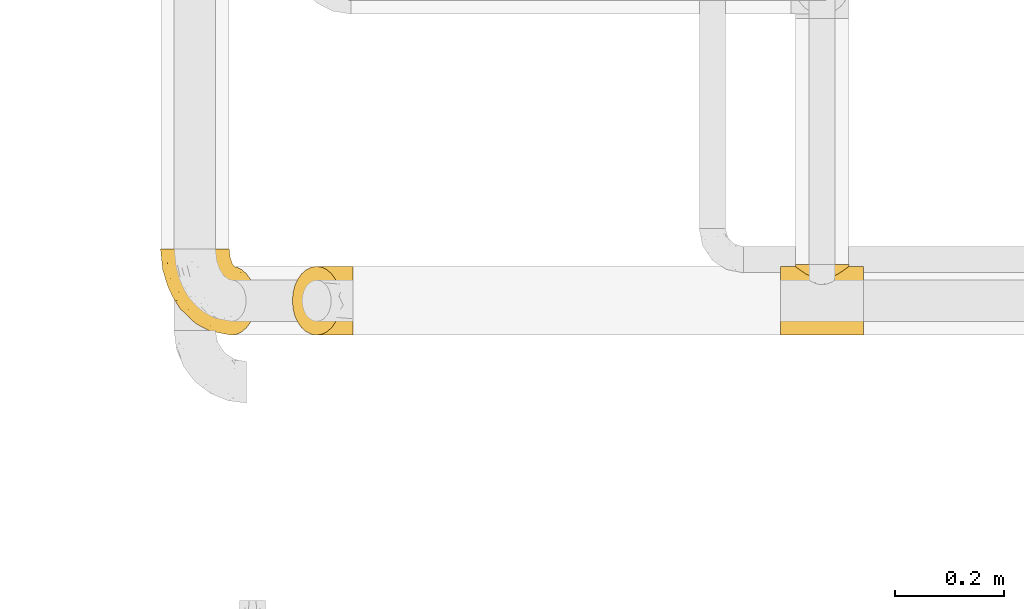
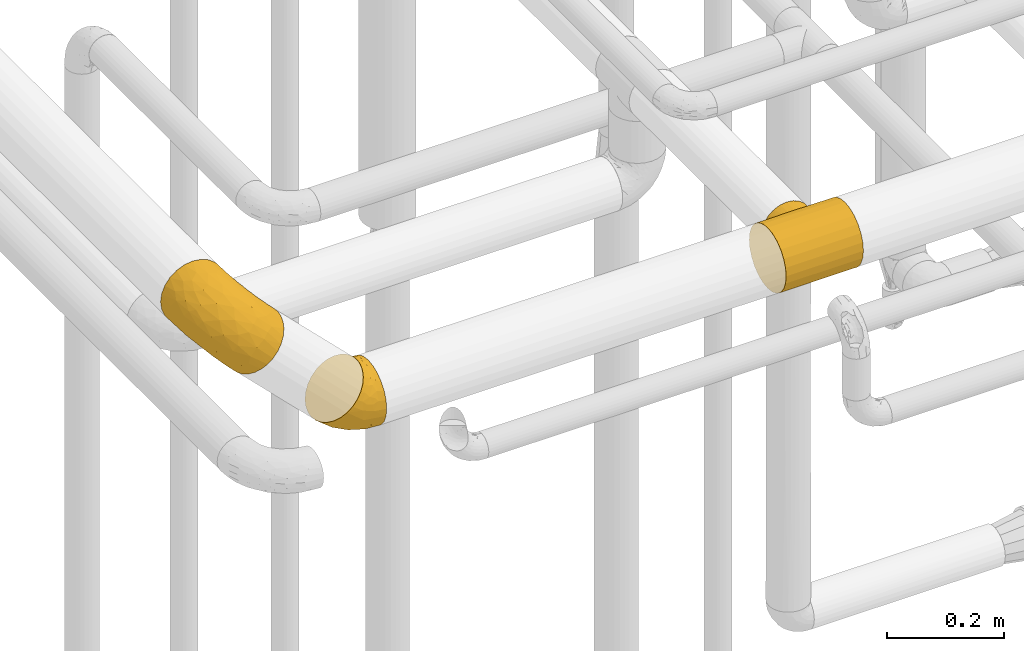
# One storey, part 418 of 827: 3 coverings.
"""IFC2X3 building model written with IfcOpenShell, lengths in millimetres."""

from ifc_helpers import new_model, entity, si_unit, converted_unit, derived_unit, direction, frame, origin, place, context, subcontext, project, spatial, faceted_brep, element, save


model = new_model("IFC2X3")

# Units and contexts
model_context = context("Model", 3, precision=0.01, world=origin(), true_north=direction((6.12303176911189e-17, 1.0)))
body_context = subcontext(model_context, "Body", "Model", "MODEL_VIEW")
ifc_project = project(units=[si_unit("LENGTHUNIT", "METRE", prefix="MILLI"), si_unit("AREAUNIT", "SQUARE_METRE"), si_unit("VOLUMEUNIT", "CUBIC_METRE"), converted_unit("PLANEANGLEUNIT", "DEGREE", entity("IfcRatioMeasure", 0.0174532925199433), si_unit("PLANEANGLEUNIT", "RADIAN"), dimensions=[0, 0, 0, 0, 0, 0, 0]), si_unit("MASSUNIT", "GRAM", prefix="KILO"), derived_unit("MASSDENSITYUNIT", [(si_unit("MASSUNIT", "GRAM", prefix="KILO"), 1), (si_unit("LENGTHUNIT", "METRE"), -3)]), derived_unit("MOMENTOFINERTIAUNIT", [(si_unit("LENGTHUNIT", "METRE"), 4)]), si_unit("TIMEUNIT", "SECOND"), si_unit("FREQUENCYUNIT", "HERTZ"), si_unit("THERMODYNAMICTEMPERATUREUNIT", "DEGREE_CELSIUS"), derived_unit("THERMALTRANSMITTANCEUNIT", [(si_unit("MASSUNIT", "GRAM", prefix="KILO"), 1), (si_unit("THERMODYNAMICTEMPERATUREUNIT", "KELVIN"), -1), (si_unit("TIMEUNIT", "SECOND"), -3)]), derived_unit("VOLUMETRICFLOWRATEUNIT", [(si_unit("LENGTHUNIT", "METRE"), 3), (si_unit("TIMEUNIT", "SECOND"), -1)]), derived_unit("MASSFLOWRATEUNIT", [(si_unit("MASSUNIT", "GRAM", prefix="KILO"), 1), (si_unit("TIMEUNIT", "SECOND"), -1)]), derived_unit("ROTATIONALFREQUENCYUNIT", [(si_unit("TIMEUNIT", "SECOND"), -1)]), si_unit("ELECTRICCURRENTUNIT", "AMPERE"), si_unit("ELECTRICVOLTAGEUNIT", "VOLT"), si_unit("POWERUNIT", "WATT"), si_unit("FORCEUNIT", "NEWTON", prefix="KILO"), si_unit("ILLUMINANCEUNIT", "LUX"), si_unit("LUMINOUSFLUXUNIT", "LUMEN"), si_unit("LUMINOUSINTENSITYUNIT", "CANDELA"), derived_unit("USERDEFINED", [(si_unit("MASSUNIT", "GRAM", prefix="KILO"), -1), (si_unit("LENGTHUNIT", "METRE"), -2), (si_unit("TIMEUNIT", "SECOND"), 3), (si_unit("LUMINOUSFLUXUNIT", "LUMEN"), 1)]), derived_unit("LINEARVELOCITYUNIT", [(si_unit("LENGTHUNIT", "METRE"), 1), (si_unit("TIMEUNIT", "SECOND"), -1)]), si_unit("PRESSUREUNIT", "PASCAL"), derived_unit("USERDEFINED", [(si_unit("LENGTHUNIT", "METRE"), -2), (si_unit("MASSUNIT", "GRAM", prefix="KILO"), 1), (si_unit("TIMEUNIT", "SECOND"), -2)]), derived_unit("LINEARFORCEUNIT", [(si_unit("MASSUNIT", "GRAM", prefix="KILO"), 1), (si_unit("LENGTHUNIT", "METRE"), 1), (si_unit("TIMEUNIT", "SECOND"), -2), (si_unit("LENGTHUNIT", "METRE"), -1)]), derived_unit("PLANARFORCEUNIT", [(si_unit("MASSUNIT", "GRAM", prefix="KILO"), 1), (si_unit("LENGTHUNIT", "METRE"), 1), (si_unit("TIMEUNIT", "SECOND"), -2), (si_unit("LENGTHUNIT", "METRE"), -2)])], contexts=[model_context])

# Site, building, storey
site_placement = place(None, origin())
site = spatial("IfcSite", under=ifc_project, at=site_placement, CompositionType="ELEMENT")
building_placement = place(site_placement, origin())
building = spatial("IfcBuilding", under=site, at=building_placement, CompositionType="ELEMENT")
storey_placement = place(building_placement, frame((0.0, 0.0, 28200.0)))
storey = spatial("IfcBuildingStorey", under=building, at=storey_placement, Name="08", CompositionType="ELEMENT", Elevation=28200.0)

# Coverings
covering_1_placement = place(storey_placement, frame((51903.73, 16007.73, 2836.71)))
element("IfcCovering", 1, at=covering_1_placement, inside=storey, Name=":ADSK_", ObjectType=":ADSK_", PredefinedType="INSULATION", context=body_context, shape_type="Brep", body=[
    faceted_brep([(175.35, 50.62, 89.9), (172.07, 37.29, 86.6), (166.77, 25.34, 81.27), (159.73, 15.35, 74.19), (151.31, 7.84, 65.71), (141.91, 3.18, 56.26), (132.02, 1.6, 46.31), (122.13, 3.18, 36.36), (112.73, 7.84, 26.91), (104.3, 15.35, 18.43), (97.27, 25.33, 11.35), (91.97, 37.29, 6.02), (88.68, 50.61, 2.72), (87.57, 64.65, 1.6), (88.68, 78.67, 2.72), (91.97, 92.0, 6.02), (97.26, 103.95, 11.35), (104.3, 113.94, 18.43), (112.73, 121.45, 26.91), (122.12, 126.11, 36.36), (132.02, 127.7, 46.31), (141.91, 126.11, 56.26), (151.3, 121.45, 65.71), (159.73, 113.94, 74.19), (166.77, 103.96, 81.27), (172.07, 92.0, 86.59), (175.35, 78.68, 89.9), (176.47, 64.65, 91.02), (109.36, 159.65, 68.83), (96.33, 159.65, 58.78), (81.14, 159.65, 52.43), (64.83, 159.65, 50.24), (48.51, 159.65, 52.34), (33.28, 159.65, 58.59), (28.78, 159.65, 62.02), (20.19, 159.65, 68.57), (10.14, 159.65, 81.6), (3.79, 159.65, 96.79), (1.6, 159.65, 113.1), (3.7, 159.65, 129.43), (9.95, 159.65, 144.65), (19.93, 159.65, 157.74), (32.96, 159.65, 167.8), (48.15, 159.65, 174.14), (64.46, 159.65, 176.34), (80.78, 159.65, 174.24), (96.01, 159.65, 167.98), (109.1, 159.65, 158.0), (115.7, 159.65, 149.45), (119.15, 159.65, 144.97), (125.5, 159.65, 129.78), (127.69, 159.65, 113.47), (125.59, 159.65, 97.15), (119.34, 159.65, 81.92), (55.85, 131.11, 173.43), (41.66, 121.84, 167.26), (60.37, 98.59, 165.56), (30.26, 132.73, 163.38), (23.75, 118.74, 153.94), (115.09, 45.67, 131.87), (95.71, 62.3, 147.86), (83.02, 49.95, 140.46), (58.27, 65.74, 147.01), (34.95, 80.62, 142.81), (52.76, 47.89, 125.1), (86.52, 117.53, 168.96), (83.08, 90.48, 162.78), (100.43, 98.53, 159.78), (97.71, 128.08, 165.64), (109.77, 107.83, 155.85), (117.7, 30.59, 118.55), (106.34, 23.56, 112.96), (128.56, 14.41, 94.06), (48.91, 94.66, 160.6), (35.83, 103.54, 157.62), (72.38, 121.36, 172.36), (103.01, 6.98, 75.15), (118.58, 9.17, 86.36), (76.46, 35.7, 124.55), (93.76, 18.43, 103.65), (129.71, 57.25, 130.67), (120.01, 81.84, 144.59), (109.87, 72.43, 147.74), (157.78, 56.38, 108.16), (151.24, 43.86, 108.97), (121.96, 103.81, 145.21), (117.18, 117.05, 149.97), (112.39, 130.29, 154.72), (140.64, 21.28, 97.63), (136.51, 34.21, 112.94), (75.74, 74.07, 156.07), (136.87, 82.79, 130.39), (133.14, 88.04, 134.1), (129.42, 93.3, 137.8), (167.68, 66.61, 99.76), (161.66, 67.95, 105.74), (155.65, 69.29, 111.72), (138.98, 66.64, 126.81), (146.26, 76.04, 121.06), (75.97, 22.77, 102.02), (110.49, 147.25, 156.62), (138.95, 120.78, 107.68), (135.84, 128.88, 94.92), (133.4, 132.53, 106.71), (118.56, 145.71, 146.5), (127.03, 132.18, 133.07), (123.45, 121.21, 142.13), (128.82, 115.88, 135.23), (120.97, 134.78, 143.82), (134.18, 113.68, 126.87), (133.01, 124.96, 121.96), (158.42, 105.67, 88.96), (148.96, 116.22, 85.8), (151.61, 103.69, 102.12), (127.74, 149.68, 102.67), (129.9, 142.04, 112.35), (124.93, 151.17, 92.07), (129.16, 140.2, 93.76), (125.43, 145.72, 132.4), (120.15, 147.4, 78.91), (133.11, 128.57, 65.74), (125.59, 136.38, 74.91), (137.37, 126.93, 81.16), (157.1, 79.77, 108.94), (148.21, 89.98, 116.32), (165.6, 79.6, 99.68), (120.69, 131.98, 57.57), (159.37, 90.59, 101.79), (127.75, 129.31, 50.55), (131.63, 133.25, 84.68), (142.77, 119.53, 95.49), (144.86, 111.1, 106.35), (128.26, 143.67, 122.92), (142.95, 123.62, 71.67), (145.48, 100.76, 114.84), (112.39, 143.67, 65.82), (130.77, 104.28, 135.16), (139.87, 112.26, 116.34), (137.88, 103.95, 125.18), (141.0, 92.99, 124.55), (86.22, 151.17, 53.13), (76.66, 144.66, 49.2), (99.35, 147.4, 57.98), (21.59, 147.25, 67.19), (112.6, 128.57, 45.1), (103.38, 136.38, 52.57), (53.79, 93.43, 36.99), (64.24, 100.15, 31.77), (62.11, 89.98, 29.71), (33.06, 103.81, 55.78), (28.28, 117.05, 60.54), (36.15, 121.21, 54.32), (76.32, 103.69, 26.39), (70.21, 110.23, 33.42), (81.95, 118.45, 34.66), (34.44, 134.78, 56.78), (45.23, 132.18, 50.79), (55.39, 143.67, 49.61), (65.97, 142.04, 48.04), (70.69, 120.78, 39.02), (72.61, 132.4, 44.45), (83.49, 127.76, 41.42), (45.89, 145.72, 52.39), (31.75, 145.71, 59.18), (56.37, 124.96, 44.88), (106.72, 123.62, 35.23), (84.55, 140.2, 48.89), (78.77, 66.61, 10.34), (72.76, 67.95, 16.31), (97.19, 126.93, 40.75), (92.62, 116.21, 29.13), (76.69, 90.59, 18.63), (69.54, 79.77, 20.85), (89.52, 105.66, 19.65), (66.75, 69.29, 22.29), (78.84, 79.6, 12.41), (93.11, 133.38, 46.47), (47.97, 82.79, 40.96), (57.36, 76.04, 31.63), (43.17, 104.28, 47.03), (43.08, 115.88, 48.98), (51.48, 113.68, 43.67), (61.25, 112.97, 38.69), (40.51, 93.3, 48.37), (53.18, 103.94, 39.99), (23.49, 130.29, 65.29), (12.35, 98.59, 117.25), (4.45, 131.11, 121.73), (5.62, 121.36, 105.2), (9.1, 117.53, 91.08), (10.54, 121.84, 135.95), (19.62, 105.45, 142.34), (14.36, 132.83, 147.44), (22.35, 107.83, 67.91), (70.32, 56.38, 20.18), (69.48, 43.85, 26.72), (47.65, 57.25, 48.12), (53.45, 35.7, 101.41), (37.58, 49.95, 94.75), (65.22, 23.55, 71.6), (51.56, 66.64, 38.87), (33.67, 81.84, 57.74), (12.49, 128.08, 79.91), (18.34, 92.46, 128.9), (59.7, 30.58, 60.21), (80.75, 21.27, 37.39), (90.12, 12.64, 43.48), (46.36, 45.66, 62.73), (65.42, 34.21, 41.43), (15.26, 90.48, 94.56), (30.88, 65.74, 119.46), (18.37, 98.53, 77.23), (30.46, 72.43, 67.86), (30.25, 62.3, 82.02), (23.7, 72.15, 109.34), (27.05, 82.52, 134.73), (72.89, 19.03, 82.69), (91.89, 9.17, 59.51)], [[[0, 1, 2, 3, 4, 5, 6, 7, 8, 9, 10, 11, 12, 13, 14, 15, 16, 17, 18, 19, 20, 21, 22, 23, 24, 25, 26, 27]], [[28, 29, 30, 31, 32, 33, 34, 35, 36, 37, 38, 39, 40, 41, 42, 43, 44, 45, 46, 47, 48, 49, 50, 51, 52, 53]], [[54, 55, 56]], [[57, 41, 58]], [[59, 60, 61]], [[62, 63, 64]], [[65, 66, 67]], [[68, 67, 69]], [[70, 71, 72]], [[55, 73, 56]], [[43, 42, 55]], [[55, 74, 73]], [[44, 75, 45]], [[44, 43, 54]], [[76, 5, 77]], [[71, 78, 79]], [[45, 75, 65]], [[46, 68, 47]], [[80, 81, 82]], [[0, 83, 84]], [[69, 85, 86, 87]], [[69, 81, 85]], [[84, 1, 0]], [[2, 88, 3]], [[4, 3, 72]], [[44, 54, 75]], [[5, 4, 77]], [[89, 2, 1]], [[72, 3, 88]], [[5, 76, 6]], [[70, 88, 89]], [[68, 65, 67]], [[88, 2, 89]], [[56, 90, 66]], [[64, 78, 62]], [[81, 91, 92, 93, 85]], [[83, 27, 94, 95, 96]], [[62, 61, 90]], [[97, 96, 98, 91]], [[80, 97, 81]], [[42, 57, 55]], [[62, 78, 61]], [[84, 89, 1]], [[78, 64, 99]], [[57, 74, 55]], [[76, 77, 79]], [[77, 72, 71]], [[82, 81, 67]], [[97, 83, 96]], [[80, 89, 84]], [[79, 78, 99]], [[71, 70, 61]], [[81, 97, 91]], [[83, 80, 84]], [[68, 87, 100, 47]], [[81, 69, 67]], [[68, 69, 87]], [[65, 46, 45]], [[65, 68, 46]], [[66, 65, 75]], [[56, 66, 75]], [[66, 60, 82]], [[71, 61, 78]], [[60, 66, 90]], [[83, 97, 80]], [[27, 83, 0]], [[59, 70, 89]], [[70, 59, 61]], [[89, 80, 59]], [[82, 59, 80]], [[55, 54, 43]], [[75, 54, 56]], [[66, 82, 67]], [[59, 82, 60]], [[41, 57, 42]], [[74, 57, 58]], [[58, 63, 74]], [[62, 74, 63]], [[74, 62, 73]], [[62, 56, 73]], [[4, 72, 77]], [[70, 72, 88]], [[76, 79, 99]], [[71, 79, 77]], [[62, 90, 56]], [[60, 90, 61]], [[101, 102, 103]], [[100, 87, 104]], [[105, 106, 107]], [[108, 104, 87]], [[107, 109, 110]], [[108, 87, 86]], [[111, 112, 113]], [[114, 51, 115]], [[116, 114, 117]], [[51, 50, 118]], [[119, 28, 53]], [[120, 121, 122]], [[98, 123, 124]], [[125, 96, 95]], [[116, 53, 52]], [[126, 121, 120]], [[104, 108, 118]], [[98, 124, 91]], [[25, 24, 127]], [[120, 128, 126]], [[122, 129, 102]], [[95, 94, 27, 26]], [[122, 102, 130]], [[125, 127, 123]], [[24, 111, 127]], [[21, 20, 128]], [[112, 130, 131]], [[48, 47, 100, 49]], [[132, 110, 115]], [[23, 111, 24]], [[129, 119, 117]], [[120, 133, 21]], [[112, 23, 22]], [[134, 113, 131]], [[121, 126, 135]], [[133, 112, 22]], [[128, 120, 21]], [[132, 51, 118]], [[120, 122, 133]], [[119, 121, 135]], [[129, 117, 102]], [[125, 26, 25]], [[26, 125, 95]], [[127, 125, 25]], [[28, 119, 135]], [[119, 53, 116]], [[127, 113, 124]], [[96, 125, 123]], [[112, 131, 113]], [[101, 103, 110]], [[85, 93, 136]], [[124, 123, 127]], [[98, 96, 123]], [[112, 111, 23]], [[127, 111, 113]], [[112, 133, 122]], [[21, 133, 22]], [[107, 110, 105]], [[110, 109, 137]], [[86, 106, 108]], [[138, 109, 136]], [[105, 118, 108]], [[107, 106, 85]], [[104, 50, 49]], [[124, 134, 139]], [[138, 93, 92]], [[92, 91, 139]], [[100, 104, 49]], [[118, 105, 132]], [[104, 118, 50]], [[110, 132, 105]], [[51, 132, 115]], [[108, 106, 105]], [[85, 106, 86]], [[114, 116, 52]], [[119, 116, 117]], [[51, 114, 52]], [[114, 115, 103]], [[117, 114, 103]], [[130, 102, 101]], [[117, 103, 102]], [[110, 103, 115]], [[130, 101, 131]], [[122, 130, 112]], [[101, 137, 131]], [[113, 134, 124]], [[137, 134, 131]], [[124, 139, 91]], [[134, 138, 139]], [[92, 139, 138]], [[110, 137, 101]], [[134, 137, 138]], [[136, 109, 107]], [[137, 109, 138]], [[85, 136, 107]], [[138, 136, 93]], [[122, 121, 129]], [[129, 121, 119]], [[30, 140, 141]], [[30, 29, 140]], [[28, 135, 142]], [[143, 35, 34, 33]], [[19, 144, 128]], [[126, 145, 135]], [[146, 147, 148]], [[149, 150, 151]], [[152, 153, 154]], [[155, 156, 151]], [[157, 31, 158]], [[159, 160, 161]], [[32, 162, 163]], [[158, 31, 30]], [[157, 164, 156]], [[126, 144, 145]], [[126, 128, 144]], [[18, 165, 19]], [[141, 166, 160]], [[14, 13, 167, 168]], [[163, 143, 33]], [[169, 165, 170]], [[18, 17, 170]], [[153, 159, 154]], [[142, 135, 145]], [[148, 171, 172]], [[159, 161, 154]], [[171, 152, 173]], [[173, 17, 16]], [[16, 15, 171]], [[158, 160, 164]], [[174, 175, 168]], [[173, 170, 17]], [[19, 128, 20]], [[174, 172, 175]], [[165, 169, 144]], [[162, 157, 156]], [[175, 172, 171]], [[144, 169, 145]], [[176, 169, 161]], [[166, 140, 142]], [[175, 171, 15]], [[168, 175, 14]], [[14, 175, 15]], [[142, 145, 176]], [[28, 142, 29]], [[148, 177, 146]], [[148, 178, 177]], [[152, 171, 148]], [[179, 180, 181]], [[164, 180, 156]], [[174, 178, 172]], [[148, 172, 178]], [[171, 173, 16]], [[170, 173, 152]], [[19, 165, 144]], [[170, 165, 18]], [[153, 182, 159]], [[146, 183, 184]], [[181, 180, 164]], [[180, 151, 156]], [[163, 155, 185]], [[155, 150, 185]], [[162, 156, 155]], [[143, 163, 185]], [[180, 179, 149]], [[32, 163, 33]], [[163, 162, 155]], [[31, 162, 32]], [[31, 157, 162]], [[164, 157, 158]], [[149, 151, 180]], [[155, 151, 150]], [[142, 140, 29]], [[141, 140, 166]], [[176, 145, 169]], [[30, 141, 158]], [[164, 160, 159]], [[158, 141, 160]], [[166, 161, 160]], [[154, 169, 170]], [[169, 154, 161]], [[152, 154, 170]], [[147, 152, 148]], [[153, 147, 182]], [[181, 182, 184]], [[164, 159, 182]], [[161, 166, 176]], [[142, 176, 166]], [[183, 146, 177]], [[184, 182, 147]], [[184, 147, 146]], [[152, 147, 153]], [[182, 181, 164]], [[179, 184, 183]], [[184, 179, 181]], [[149, 179, 183]], [[186, 187, 188]], [[37, 36, 189]], [[190, 191, 192]], [[193, 185, 150, 149]], [[194, 195, 196]], [[197, 198, 199]], [[200, 201, 177]], [[193, 202, 185]], [[203, 190, 186]], [[202, 189, 36]], [[41, 40, 192]], [[204, 205, 199]], [[9, 8, 206]], [[187, 190, 39]], [[40, 39, 190]], [[38, 37, 188]], [[207, 208, 204]], [[202, 35, 143, 185]], [[39, 38, 187]], [[195, 11, 208]], [[201, 149, 183, 177]], [[188, 189, 209]], [[197, 64, 210]], [[186, 188, 209]], [[13, 12, 194]], [[211, 201, 212]], [[12, 11, 195]], [[193, 201, 211]], [[212, 201, 196]], [[10, 208, 11]], [[213, 214, 209]], [[64, 63, 215]], [[216, 197, 199]], [[8, 217, 206]], [[7, 217, 8]], [[203, 191, 190]], [[7, 6, 76]], [[208, 205, 204]], [[205, 10, 9]], [[199, 205, 206]], [[7, 76, 217]], [[205, 208, 10]], [[216, 76, 99]], [[200, 177, 178, 174]], [[64, 197, 99]], [[63, 58, 191]], [[208, 196, 195]], [[196, 200, 194]], [[198, 197, 210]], [[216, 199, 217]], [[201, 193, 149]], [[202, 193, 211]], [[202, 211, 189]], [[35, 202, 36]], [[211, 212, 209]], [[37, 189, 188]], [[211, 209, 189]], [[213, 198, 214]], [[200, 174, 194]], [[201, 200, 196]], [[214, 198, 210]], [[213, 207, 198]], [[194, 174, 168, 167, 13]], [[195, 194, 12]], [[198, 204, 199]], [[204, 198, 207]], [[212, 207, 213]], [[196, 208, 207]], [[188, 187, 38]], [[190, 187, 186]], [[207, 212, 196]], [[209, 212, 213]], [[214, 203, 186]], [[191, 215, 63]], [[191, 203, 215]], [[192, 191, 58]], [[41, 192, 58]], [[190, 192, 40]], [[203, 210, 215]], [[64, 215, 210]], [[199, 206, 217]], [[9, 206, 205]], [[76, 216, 217]], [[99, 197, 216]], [[203, 214, 210]], [[209, 214, 186]]]),
])
covering_2_placement = place(storey_placement, frame((52146.02, 16007.73, 2635.35)))
element("IfcCovering", 2, at=covering_2_placement, inside=storey, Name=":ADSK_", ObjectType=":ADSK_", PredefinedType="INSULATION", context=body_context, shape_type="Brep", body=[
    faceted_brep([(89.38, 78.67, 135.87), (86.1, 92.0, 132.56), (80.8, 103.95, 127.23), (73.76, 113.94, 120.15), (65.34, 121.45, 111.68), (55.94, 126.11, 102.23), (46.05, 127.7, 92.27), (36.16, 126.11, 82.32), (26.76, 121.45, 72.87), (18.33, 113.94, 64.39), (11.29, 103.96, 57.31), (6.0, 92.0, 51.99), (2.71, 78.68, 48.68), (1.6, 64.65, 47.56), (2.71, 50.62, 48.68), (6.0, 37.29, 51.99), (11.29, 25.34, 57.31), (18.33, 15.35, 64.39), (26.76, 7.84, 72.87), (36.15, 3.18, 82.32), (46.05, 1.6, 92.27), (55.94, 3.18, 102.22), (65.33, 7.84, 111.67), (73.76, 15.35, 120.15), (80.8, 25.33, 127.23), (86.1, 37.29, 132.56), (89.38, 50.61, 135.87), (90.5, 64.65, 136.99), (113.02, 64.65, 127.7), (113.02, 48.33, 125.55), (113.02, 33.12, 119.25), (113.02, 20.06, 109.23), (113.02, 10.04, 96.17), (113.02, 3.74, 80.96), (113.02, 1.6, 64.65), (113.02, 3.74, 48.33), (113.02, 10.04, 33.12), (113.02, 20.06, 20.06), (113.02, 33.12, 10.04), (113.02, 48.33, 3.74), (113.02, 64.65, 1.6), (113.02, 80.96, 3.74), (113.02, 96.17, 10.04), (113.02, 109.23, 20.06), (113.02, 119.25, 33.12), (113.02, 125.55, 48.33), (113.02, 127.7, 64.65), (113.02, 125.55, 80.96), (113.02, 119.25, 96.17), (113.02, 109.23, 109.23), (113.02, 96.17, 119.25), (113.02, 80.96, 125.55), (38.2, 108.11, 40.53), (72.27, 64.65, 6.94), (85.02, 102.06, 16.61), (34.27, 64.65, 22.61), (64.87, 81.3, 11.46), (69.54, 124.75, 54.23), (87.61, 117.87, 33.38), (67.84, 113.03, 31.98), (65.99, 119.86, 43.36), (31.04, 84.61, 28.33), (88.53, 127.7, 67.86), (100.56, 127.7, 66.28), (28.51, 97.33, 37.03), (55.17, 96.31, 21.77), (42.34, 117.13, 50.61), (85.71, 90.59, 9.65), (56.04, 127.7, 84.65), (65.69, 127.7, 77.28), (77.11, 127.7, 72.57), (75.18, 120.26, 106.43), (66.61, 125.89, 94.45), (98.68, 125.09, 83.95), (98.65, 117.9, 100.1), (85.15, 112.3, 113.73), (82.86, 122.52, 96.49), (95.66, 102.17, 118.86), (104.59, 105.15, 113.73), (94.91, 111.51, 110.03), (105.87, 74.37, 127.73), (96.93, 87.76, 127.06), (97.06, 75.98, 130.79), (75.58, 126.58, 85.36), (86.39, 126.44, 81.58), (105.62, 90.36, 122.95), (92.71, 123.15, 91.1), (100.84, 64.65, 130.11), (96.93, 41.53, 127.06), (85.14, 16.99, 113.72), (103.59, 52.09, 127.8), (98.64, 11.39, 100.1), (98.68, 4.21, 83.95), (103.77, 35.35, 121.59), (95.65, 27.12, 118.85), (100.56, 1.6, 66.28), (75.58, 2.71, 85.35), (65.69, 1.6, 77.28), (77.11, 1.6, 72.57), (92.71, 6.14, 91.1), (82.85, 6.77, 96.49), (86.39, 2.85, 81.58), (104.6, 24.15, 113.73), (94.91, 17.78, 110.02), (75.18, 9.03, 106.43), (66.6, 3.4, 94.45), (56.04, 1.6, 84.65), (88.53, 1.6, 67.86), (69.54, 4.54, 54.23), (65.98, 9.43, 43.37), (87.6, 11.42, 33.38), (31.04, 44.69, 28.33), (28.51, 31.97, 37.03), (38.2, 21.18, 40.52), (42.34, 12.17, 50.61), (67.83, 16.26, 31.98), (85.02, 27.23, 16.61), (55.17, 32.98, 21.77), (85.71, 38.7, 9.65), (64.87, 47.99, 11.46)], [[[0, 1, 2, 3, 4, 5, 6, 7, 8, 9, 10, 11, 12, 13, 14, 15, 16, 17, 18, 19, 20, 21, 22, 23, 24, 25, 26, 27]], [[28, 29, 30, 31, 32, 33, 34, 35, 36, 37, 38, 39, 40, 41, 42, 43, 44, 45, 46, 47, 48, 49, 50, 51]], [[52, 10, 9]], [[41, 40, 53]], [[42, 54, 43]], [[53, 55, 56]], [[8, 7, 57]], [[58, 59, 60]], [[55, 12, 61]], [[58, 43, 59]], [[45, 62, 63, 46]], [[62, 45, 57]], [[45, 44, 58]], [[64, 52, 65]], [[54, 59, 43]], [[59, 65, 52]], [[61, 56, 55]], [[61, 65, 56]], [[52, 9, 66]], [[64, 11, 10]], [[64, 61, 11]], [[12, 55, 13]], [[59, 54, 65]], [[67, 54, 42]], [[41, 56, 67]], [[61, 64, 65]], [[66, 9, 8]], [[7, 6, 68, 69]], [[57, 69, 70, 62]], [[57, 7, 69]], [[59, 52, 66]], [[57, 66, 8]], [[59, 66, 60]], [[41, 53, 56]], [[52, 64, 10]], [[61, 12, 11]], [[41, 67, 42]], [[65, 54, 67]], [[65, 67, 56]], [[66, 57, 60]], [[57, 45, 58]], [[58, 60, 57]], [[43, 58, 44]], [[71, 72, 4]], [[62, 73, 63]], [[48, 74, 49]], [[63, 73, 47]], [[74, 48, 73]], [[71, 75, 76]], [[77, 78, 79]], [[77, 2, 1]], [[80, 28, 51]], [[81, 82, 80]], [[72, 76, 83]], [[62, 70, 84]], [[81, 85, 77]], [[50, 85, 51]], [[84, 86, 73]], [[68, 72, 69]], [[4, 3, 71]], [[72, 5, 4]], [[73, 48, 47]], [[72, 68, 5]], [[79, 76, 75]], [[69, 83, 70]], [[2, 77, 75]], [[87, 82, 27]], [[82, 81, 0]], [[0, 81, 1]], [[2, 75, 3]], [[50, 49, 78]], [[1, 81, 77]], [[79, 75, 77]], [[72, 71, 76]], [[75, 71, 3]], [[70, 83, 84]], [[68, 6, 5]], [[72, 83, 69]], [[74, 86, 76]], [[76, 84, 83]], [[62, 84, 73]], [[47, 46, 63]], [[76, 86, 84]], [[74, 73, 86]], [[74, 78, 49]], [[85, 78, 77]], [[78, 74, 79]], [[76, 79, 74]], [[27, 82, 0]], [[80, 82, 87]], [[28, 80, 87]], [[80, 51, 85]], [[85, 50, 78]], [[80, 85, 81]], [[26, 25, 88]], [[24, 23, 89]], [[87, 90, 28]], [[32, 91, 92]], [[93, 88, 94]], [[93, 29, 90]], [[92, 95, 33]], [[96, 97, 98]], [[92, 91, 99]], [[100, 101, 99]], [[102, 94, 103]], [[92, 33, 32]], [[104, 89, 23]], [[101, 96, 98]], [[90, 26, 88]], [[96, 105, 97]], [[88, 25, 94]], [[100, 96, 101]], [[24, 89, 94]], [[31, 91, 32]], [[31, 30, 102]], [[94, 25, 24]], [[22, 21, 105]], [[104, 23, 22]], [[88, 93, 90]], [[31, 102, 91]], [[97, 105, 106]], [[105, 21, 106]], [[104, 105, 100]], [[100, 91, 103]], [[105, 104, 22]], [[26, 87, 27]], [[89, 104, 100]], [[21, 20, 106]], [[92, 101, 107]], [[105, 96, 100]], [[107, 101, 98]], [[101, 92, 99]], [[95, 92, 107]], [[95, 34, 33]], [[100, 99, 91]], [[93, 102, 30]], [[94, 89, 103]], [[100, 103, 89]], [[91, 102, 103]], [[102, 93, 94]], [[29, 93, 30]], [[28, 90, 29]], [[26, 90, 87]], [[108, 109, 110]], [[111, 112, 15]], [[35, 34, 95, 107]], [[113, 114, 17]], [[109, 114, 115]], [[116, 115, 117]], [[40, 39, 53]], [[117, 118, 116]], [[111, 119, 117]], [[115, 116, 37]], [[110, 37, 36]], [[38, 116, 118]], [[118, 117, 119]], [[19, 18, 108]], [[108, 107, 98, 97]], [[113, 112, 117]], [[19, 97, 106, 20]], [[37, 116, 38]], [[113, 17, 16]], [[53, 39, 119]], [[117, 115, 113]], [[108, 35, 107]], [[118, 39, 38]], [[114, 18, 17]], [[119, 111, 55]], [[112, 16, 15]], [[14, 13, 55]], [[14, 55, 111]], [[108, 18, 114]], [[112, 111, 117]], [[119, 55, 53]], [[14, 111, 15]], [[112, 113, 16]], [[19, 108, 97]], [[113, 115, 114]], [[35, 108, 110]], [[39, 118, 119]], [[110, 109, 115]], [[108, 114, 109]], [[37, 110, 115]], [[35, 110, 36]]]),
])
covering_3_placement = place(storey_placement, frame((53045.06, 16007.73, 2635.39)))
element("IfcCovering", 3, at=covering_3_placement, inside=storey, Name=":ADSK_", ObjectType=":ADSK_", PredefinedType="INSULATION", context=body_context, shape_type="Brep", body=[
    faceted_brep([(0.0, 10.04, 33.12), (0.0, 3.74, 48.33), (0.0, 1.6, 64.65), (0.0, 3.74, 80.96), (0.0, 10.04, 96.17), (0.0, 20.06, 109.23), (0.0, 33.12, 119.25), (0.0, 48.33, 125.55), (0.0, 64.65, 127.7), (0.0, 80.96, 125.55), (0.0, 96.17, 119.25), (0.0, 109.23, 109.23), (0.0, 114.24, 102.7), (0.0, 119.25, 96.17), (0.0, 122.4, 88.57), (0.0, 125.55, 80.96), (0.0, 126.62, 72.8), (0.0, 127.7, 64.65), (0.0, 126.62, 56.49), (0.0, 125.55, 48.33), (0.0, 122.4, 40.72), (0.0, 119.25, 33.12), (0.0, 114.24, 26.59), (0.0, 109.23, 20.06), (0.0, 96.17, 10.04), (0.0, 80.96, 3.74), (0.0, 64.65, 1.6), (0.0, 48.33, 3.74), (0.0, 33.12, 10.04), (0.0, 20.06, 20.06), (152.0, 64.65, 127.7), (152.0, 48.33, 125.55), (152.0, 33.12, 119.25), (152.0, 20.06, 109.23), (152.0, 10.04, 96.17), (152.0, 3.74, 80.96), (152.0, 1.6, 64.65), (152.0, 3.74, 48.33), (152.0, 10.04, 33.12), (152.0, 20.06, 20.06), (152.0, 33.12, 10.04), (152.0, 48.33, 3.74), (152.0, 64.65, 1.6), (152.0, 80.96, 3.74), (152.0, 96.17, 10.04), (152.0, 109.23, 20.06), (152.0, 114.24, 26.59), (152.0, 119.25, 33.12), (152.0, 122.4, 40.72), (152.0, 125.55, 48.33), (152.0, 126.62, 56.49), (152.0, 127.7, 64.65), (152.0, 126.62, 72.8), (152.0, 125.55, 80.96), (152.0, 122.4, 88.57), (152.0, 119.25, 96.17), (152.0, 114.24, 102.7), (152.0, 109.23, 109.23), (152.0, 96.17, 119.25), (152.0, 80.96, 125.55), (106.57, 114.58, 103.13), (97.67, 109.69, 108.76), (114.06, 119.49, 95.74), (32.06, 123.72, 86.67), (87.39, 105.75, 112.46), (76.0, 104.14, 113.8), (64.61, 105.75, 112.46), (27.53, 127.17, 70.38), (26.85, 127.7, 64.65), (125.15, 127.7, 64.65), (124.47, 127.17, 70.38), (45.43, 114.58, 103.13), (54.33, 109.69, 108.76), (37.94, 119.49, 95.74), (119.94, 123.72, 86.67), (30.13, 125.18, 81.39), (28.21, 126.64, 76.12), (123.79, 126.64, 76.12), (121.87, 125.18, 81.39), (124.47, 127.17, 58.91), (123.79, 126.64, 53.17), (114.06, 119.49, 33.55), (119.94, 123.72, 42.62), (121.87, 125.18, 47.9), (28.21, 126.64, 53.17), (27.53, 127.17, 58.91), (37.94, 119.49, 33.55), (32.06, 123.72, 42.62), (45.43, 114.58, 26.16), (30.13, 125.18, 47.9), (106.57, 114.58, 26.16), (97.67, 109.69, 20.53), (87.39, 105.75, 16.83), (76.0, 104.14, 15.5), (54.33, 109.69, 20.53), (64.61, 105.75, 16.83), (88.72, 131.65, 112.12), (100.58, 131.65, 107.21), (110.75, 131.65, 99.4), (118.57, 131.65, 89.22), (121.02, 131.65, 83.29), (123.48, 131.65, 77.37), (124.31, 131.65, 71.01), (125.15, 131.65, 64.65), (124.31, 131.65, 58.28), (123.48, 131.65, 51.92), (121.02, 131.65, 46.0), (118.57, 131.65, 40.07), (110.75, 131.65, 29.89), (100.58, 131.65, 22.08), (88.72, 131.65, 17.17), (76.0, 131.65, 15.5), (63.28, 131.65, 17.17), (51.42, 131.65, 22.08), (41.25, 131.65, 29.89), (33.43, 131.65, 40.07), (30.98, 131.65, 46.0), (28.52, 131.65, 51.92), (27.69, 131.65, 58.28), (26.85, 131.65, 64.65), (27.69, 131.65, 71.01), (28.52, 131.65, 77.37), (30.98, 131.65, 83.29), (33.43, 131.65, 89.22), (41.25, 131.65, 99.4), (51.42, 131.65, 107.21), (63.28, 131.65, 112.12), (76.0, 131.65, 113.8)], [[[0, 1, 2, 3, 4, 5, 6, 7, 8, 9, 10, 11, 12, 13, 14, 15, 16, 17, 18, 19, 20, 21, 22, 23, 24, 25, 26, 27, 28, 29]], [[30, 31, 32, 33, 34, 35, 36, 37, 38, 39, 40, 41, 42, 43, 44, 45, 46, 47, 48, 49, 50, 51, 52, 53, 54, 55, 56, 57, 58, 59]], [[34, 33, 5, 4]], [[2, 36, 35, 3]], [[4, 3, 35, 34]], [[6, 32, 31, 7]], [[7, 31, 30, 8]], [[5, 33, 32, 6]], [[59, 9, 8, 30]], [[58, 10, 9, 59]], [[57, 60, 61]], [[56, 55, 62]], [[63, 15, 14]], [[61, 64, 57]], [[60, 57, 56]], [[57, 64, 58]], [[64, 65, 58]], [[66, 11, 10]], [[17, 67, 68]], [[69, 70, 51]], [[71, 11, 72]], [[72, 11, 66]], [[73, 12, 71]], [[66, 10, 65]], [[65, 10, 58]], [[62, 54, 74]], [[54, 62, 55]], [[74, 54, 53]], [[15, 63, 75, 76]], [[77, 53, 52]], [[51, 70, 52]], [[77, 52, 70]], [[53, 77, 78, 74]], [[73, 13, 12]], [[73, 14, 13]], [[14, 73, 63]], [[16, 76, 67]], [[71, 12, 11]], [[17, 16, 67]], [[16, 15, 76]], [[60, 56, 62]], [[50, 79, 51]], [[80, 50, 49]], [[47, 81, 48]], [[82, 48, 81]], [[82, 49, 48]], [[49, 82, 83, 80]], [[50, 80, 79]], [[84, 18, 85]], [[85, 17, 68]], [[51, 79, 69]], [[86, 21, 20]], [[17, 85, 18]], [[20, 19, 87]], [[86, 88, 22]], [[87, 19, 84, 89]], [[81, 46, 90]], [[81, 47, 46]], [[90, 45, 91]], [[45, 90, 46]], [[91, 45, 92]], [[24, 44, 43, 25]], [[93, 92, 44]], [[44, 92, 45]], [[43, 42, 26, 25]], [[84, 19, 18]], [[94, 95, 23]], [[86, 20, 87]], [[22, 21, 86]], [[23, 88, 94]], [[95, 24, 23]], [[93, 24, 95]], [[93, 44, 24]], [[88, 23, 22]], [[27, 41, 40, 28]], [[28, 40, 39, 29]], [[42, 41, 27, 26]], [[0, 38, 37, 1]], [[1, 37, 36, 2]], [[29, 39, 38, 0]], [[96, 97, 98, 99, 100, 101, 102, 103, 104, 105, 106, 107, 108, 109, 110, 111, 112, 113, 114, 115, 116, 117, 118, 119, 120, 121, 122, 123, 124, 125, 126, 127]], [[77, 102, 101]], [[74, 100, 99]], [[103, 70, 69]], [[103, 102, 70]], [[101, 78, 77]], [[62, 74, 99]], [[100, 78, 101]], [[100, 74, 78]], [[99, 98, 62]], [[60, 98, 97]], [[96, 127, 64]], [[102, 77, 70]], [[61, 97, 96]], [[60, 97, 61]], [[64, 61, 96]], [[65, 64, 127]], [[98, 60, 62]], [[66, 127, 126]], [[72, 126, 125]], [[65, 127, 66]], [[119, 67, 120]], [[66, 126, 72]], [[125, 71, 72]], [[125, 124, 71]], [[73, 124, 123]], [[76, 75, 121]], [[67, 119, 68]], [[76, 121, 120]], [[63, 73, 123]], [[63, 123, 122]], [[76, 120, 67]], [[122, 75, 63]], [[121, 75, 122]], [[124, 73, 71]], [[84, 118, 117]], [[87, 116, 115]], [[119, 85, 68]], [[119, 118, 85]], [[117, 89, 84]], [[86, 87, 115]], [[116, 89, 117]], [[118, 84, 85]], [[115, 114, 86]], [[88, 114, 113]], [[113, 112, 94]], [[111, 95, 112]], [[116, 87, 89]], [[88, 113, 94]], [[95, 94, 112]], [[93, 95, 111]], [[114, 88, 86]], [[92, 111, 110]], [[91, 110, 109]], [[93, 111, 92]], [[103, 79, 104]], [[92, 110, 91]], [[109, 90, 91]], [[109, 108, 90]], [[81, 108, 107]], [[80, 83, 105]], [[79, 103, 69]], [[80, 105, 104]], [[82, 81, 107]], [[82, 107, 106]], [[80, 104, 79]], [[106, 83, 82]], [[105, 83, 106]], [[108, 81, 90]]]),
])

save(model, "model.ifc")
